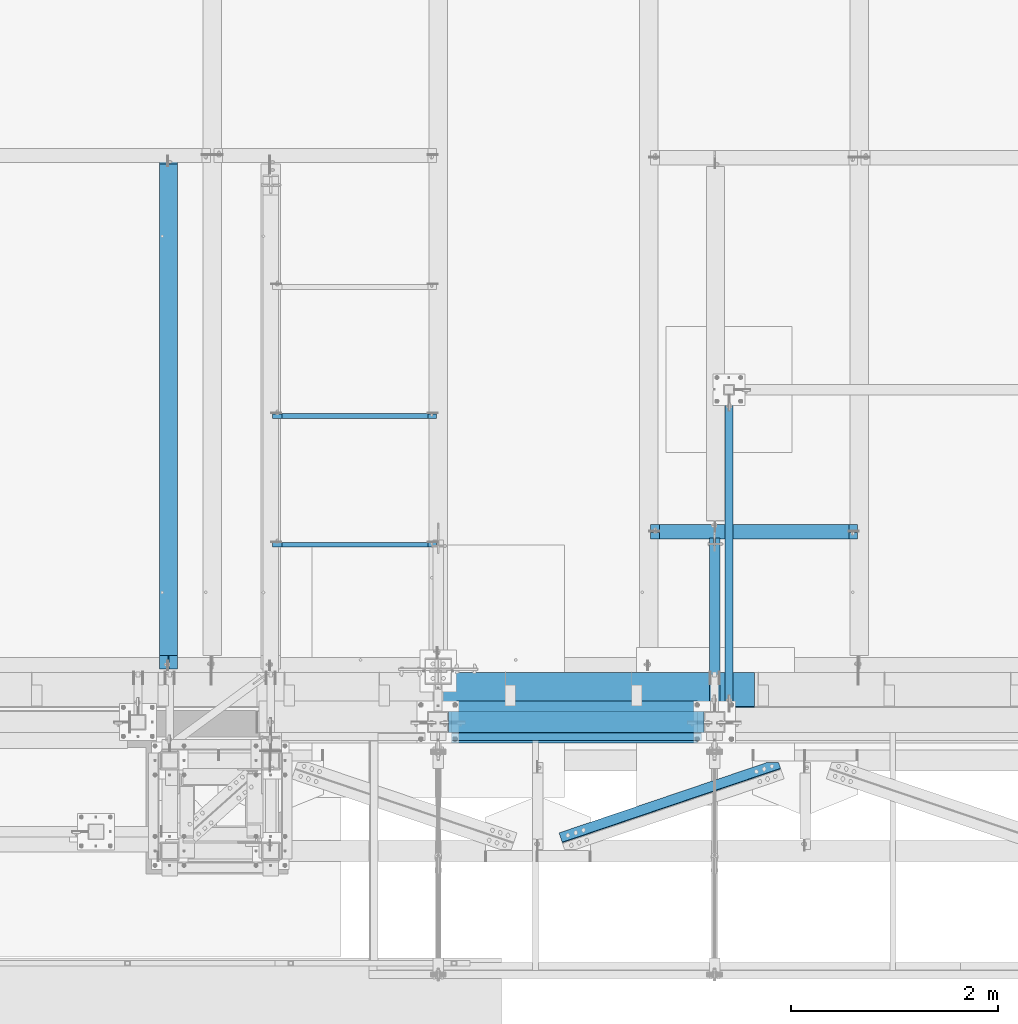
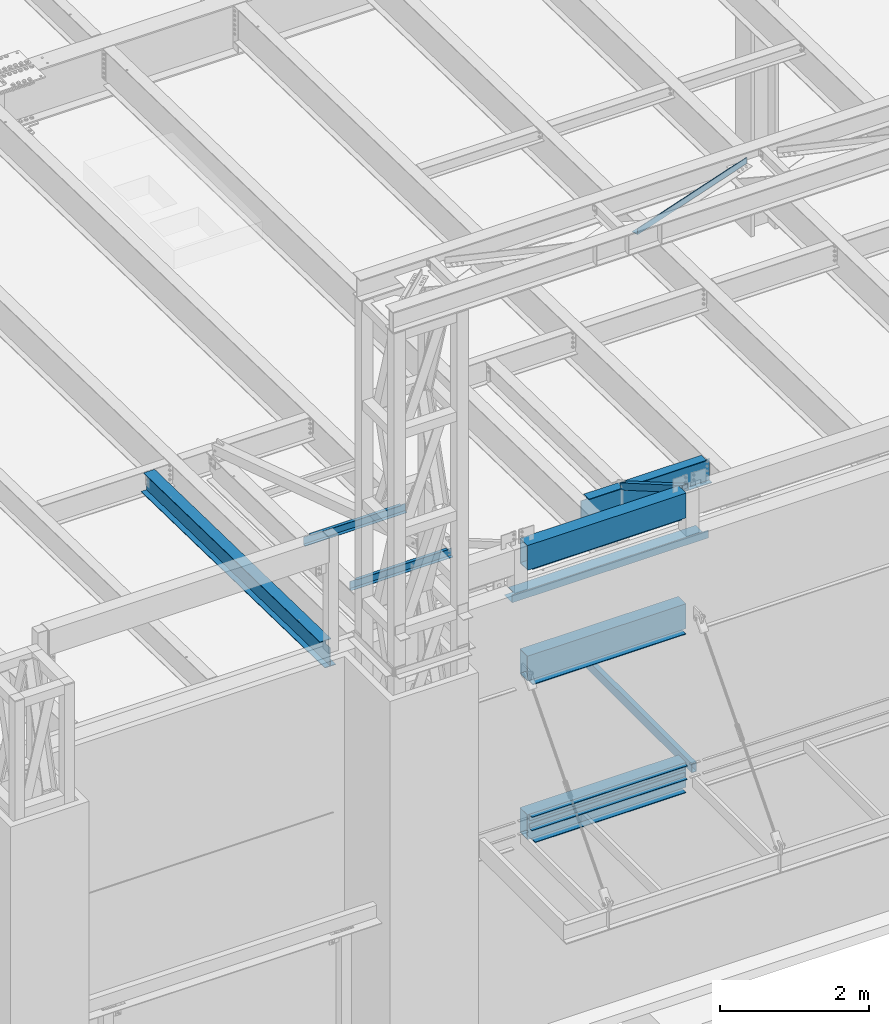
# One storey, part 1055 of 1763: 15 beams, 1 member, 11 elements without a shape of their own.
"""IFC2X3 building model written with IfcOpenShell, lengths in millimetres."""

from ifc_helpers import new_model, si_unit, frame, origin_with_axes, place, context, subcontext, project, spatial, faceted_brep, material, type_object, element, aggregate, save


model = new_model("IFC2X3")

# Units and contexts
model_context = context("Model", 3, precision=1e-05, world=origin_with_axes())
body_context = subcontext(model_context, "Body", "Model", "MODEL_VIEW")
ifc_project = project(units=[si_unit("LENGTHUNIT", "METRE", prefix="MILLI"), si_unit("AREAUNIT", "SQUARE_METRE"), si_unit("VOLUMEUNIT", "CUBIC_METRE"), si_unit("MASSUNIT", "GRAM", prefix="KILO"), si_unit("TIMEUNIT", "SECOND"), si_unit("PLANEANGLEUNIT", "RADIAN"), si_unit("SOLIDANGLEUNIT", "STERADIAN"), si_unit("THERMODYNAMICTEMPERATUREUNIT", "DEGREE_CELSIUS"), si_unit("LUMINOUSINTENSITYUNIT", "LUMEN")], contexts=[model_context])

# Site, building, storey
site_placement = place(None, origin_with_axes())
site = spatial("IfcSite", under=ifc_project, at=site_placement, CompositionType="ELEMENT")
building_placement = place(site_placement, origin_with_axes())
building = spatial("IfcBuilding", under=site, at=building_placement, Name="Undefined", CompositionType="ELEMENT")
storey_placement = place(building_placement, origin_with_axes())
storey = spatial("IfcBuildingStorey", under=building, at=storey_placement, Name="Undefined", CompositionType="ELEMENT", Elevation=0.0)

# Assembly, beam
assembly_1_placement = place(storey_placement, origin_with_axes())
assembly_1 = element("IfcElementAssembly", 1, at=assembly_1_placement, inside=storey, Name="BEAM", AssemblyPlace="NOTDEFINED", PredefinedType="RIGID_FRAME")
ifc_material_1 = material()
beam_type_1 = type_object("IfcBeamType", Name="HSS16X8X5/8", PredefinedType="NOTDEFINED")
beam_1_placement = place(assembly_1_placement, frame((-61492.8270098568, -14208.1276214906, 13055.6221257957), z_axis=(0.0, 0.0, 1.0), x_axis=(1.0, 0.0, 0.0)))
beam_1 = element("IfcBeam", 2, at=beam_1_placement, type_object=beam_type_1, material=ifc_material_1, Name="BEAM", ObjectType="HSS16X8X5/8", context=body_context, shape_type="Brep", body=[
    faceted_brep([(0.0, 85.7250000000058, -187.325), (0.0, -85.7250000000058, -187.325), (2463.80000000001, -85.7250000000004, -187.325000000001), (2463.80000000001, 85.7250000000004, -187.325000000001), (0.0, -85.7250000000058, 187.325), (2463.80000000001, -85.7250000000004, 187.325000000001), (0.0, 85.7250000000058, 187.325), (2463.80000000001, 85.7250000000004, 187.325000000001), (0.0, 101.600000000006, -203.2), (0.0, 101.600000000006, 203.2), (2463.80000000001, 101.6, 203.200000000001), (2463.80000000001, 101.6, -203.200000000001), (0.0, -101.600000000006, 203.2), (2463.80000000001, -101.6, 203.200000000001), (0.0, -101.600000000006, -203.2), (2463.80000000001, -101.6, -203.200000000001)], [[[0, 1, 2, 3]], [[1, 4, 5, 2]], [[4, 6, 7, 5]], [[6, 0, 3, 7]], [[8, 9, 10, 11]], [[9, 12, 13, 10]], [[12, 14, 15, 13]], [[14, 8, 11, 15]], [[13, 15, 11, 10], [5, 7, 3, 2]], [[14, 12, 9, 8], [6, 4, 1, 0]]]),
])

assembly_2_placement = place(storey_placement, origin_with_axes())
assembly_2 = element("IfcElementAssembly", 3, at=assembly_2_placement, inside=storey, Name="ANGLE", AssemblyPlace="NOTDEFINED", PredefinedType="RIGID_FRAME")
ifc_material_2 = material(Name="STEEL/A36")
beam_type_2 = type_object("IfcBeamType", Name="L4X4X1/4", PredefinedType="NOTDEFINED")
beam_2_placement = place(assembly_2_placement, frame((-60647.7195645886, -15404.6095930369, 18672.175), z_axis=(-0.320645554004404, 0.947199255013014, 0.0), x_axis=(0.947199255013015, 0.320645554004401, 0.0)))
beam_2 = element("IfcBeam", 4, at=beam_2_placement, type_object=beam_type_2, material=ifc_material_2, Name="ANGLE", ObjectType="L4X4X1/4", context=body_context, shape_type="Brep", body=[
    faceted_brep([(2473.98391933386, 44.4500000000007, 15.0708121723028), (2473.98391933386, 50.7999999999993, 15.0708121723028), (2368.34288178239, 50.7999999999993, 50.8000000014481), (2368.34288178239, 44.4500000000007, 50.8000000014481), (2473.9847329806, 44.4500000000007, -44.4499999985665), (2473.9847329806, -50.7999999999993, -44.4499999985665), (2473.98481932245, -50.7999999999993, -50.7999999985741), (2473.98481932245, 50.7999999999993, -50.7999999985741), (248.93475632761, 50.7999999999993, -50.7999999996973), (248.93475632761, -50.7999999999993, -50.7999999996973), (248.934670207287, -50.7999999999993, -44.449999999887), (248.934670207287, 44.4500000000007, -44.449999999887), (248.93336804508, 44.4500000000007, 50.8000000001894), (248.93336804508, 50.7999999999993, 50.8000000001894)], [[[0, 1, 2, 3]], [[4, 5, 6, 7, 1, 0]], [[8, 9, 10, 11, 12, 13]], [[13, 12, 3, 2]], [[8, 13, 2, 1, 7]], [[9, 8, 7, 6]], [[10, 9, 6, 5]], [[11, 10, 5, 4]], [[12, 11, 4, 0, 3]]]),
])
aggregate(assembly_2, [beam_2])

assembly_3_placement = place(storey_placement, origin_with_axes())
assembly_3 = element("IfcElementAssembly", 5, at=assembly_3_placement, inside=storey, Name="CHANNEL", AssemblyPlace="NOTDEFINED", PredefinedType="RIGID_FRAME")
beam_type_3 = type_object("IfcBeamType", Name="C6X8.2", PredefinedType="NOTDEFINED")
beam_3_placement = place(assembly_3_placement, frame((-63211.0608225783, -11251.4001198498, 12076.4773623998), z_axis=(0.0, 0.0, 1.0), x_axis=(1.0, 0.0, 0.0)))
beam_3 = element("IfcBeam", 6, at=beam_3_placement, type_object=beam_type_3, material=ifc_material_2, Name="CHANNEL", ObjectType="C6X8.2", context=body_context, shape_type="Brep", body=[
    faceted_brep([(94.4562501907349, 19.0499999999993, 50.7999999979074), (94.4562501907349, 23.8125, 50.7999999979074), (18.2562500000058, 23.8125, 50.7999999979074), (18.2562500000058, 19.0499999999993, 50.7999999979074), (99.3163297087813, 19.0499999999993, 51.766729920495), (99.3163297087813, 23.8125, 51.766729920495), (103.436506176935, 19.0499999999993, 54.5197438209725), (103.436506176935, 23.8125, 54.5197438209725), (106.189520077409, 19.0499999999993, 58.6399202891262), (106.189520077409, 23.8125, 58.6399202891262), (107.15625, 19.0499999999993, 63.4999998071726), (107.15625, 23.8125, 63.4999998071726), (107.15625, -23.8125, 76.2000000000007), (107.15625, 23.8125, 76.2000000000007), (107.15625, 19.0499999999993, 65.0887700000003), (107.15625, -23.8125, 72.2296624999999), (18.2562500000058, 19.0499999999993, -65.0887700000003), (18.2562500000058, -23.8125, -72.2296624999999), (1599.16104887993, -23.8125, -72.2296624999999), (1599.16104887993, 19.0499999999993, -65.0887700000003), (18.2562500000058, -23.8125, -76.2000000000007), (1599.16104887993, -23.8125, -76.2000000000007), (18.2562500000058, 23.8125, -76.2000000000007), (1599.16104887993, 23.8125, -76.2000000000007), (1599.16104887993, 23.8125, 50.8000000015836), (1599.16104887993, 19.0499999999993, 50.8000000015836), (1529.31104868917, 23.8125, 50.8000000015836), (1529.31104868917, 19.0499999999993, 50.8000000015836), (1524.45096917113, 23.8125, 51.7667299241712), (1524.45096917113, 19.0499999999993, 51.7667299241712), (1520.33079270297, 23.8125, 54.5197438246487), (1520.33079270297, 19.0499999999993, 54.5197438246487), (1517.5777788025, 23.8125, 58.6399202928023), (1517.5777788025, 19.0499999999993, 58.6399202928023), (1516.61104887991, 23.8125, 63.4999998108487), (1516.61104887991, 19.0499999999993, 63.4999998108487), (1516.61104887991, -23.8125, 76.2000000000007), (1516.61104887991, -23.8125, 72.2296624999999), (1516.61104887991, 19.0499999999993, 65.0887700000003), (1516.61104887991, 23.8125, 76.2000000000007)], [[[0, 1, 2, 3]], [[4, 5, 1, 0]], [[6, 7, 5, 4]], [[8, 9, 7, 6]], [[10, 11, 9, 8]], [[12, 13, 11, 10, 14, 15]], [[16, 17, 18, 19]], [[17, 20, 21, 18]], [[20, 22, 23, 21]], [[19, 18, 21, 23, 24, 25]], [[25, 24, 26, 27]], [[27, 26, 28, 29]], [[29, 28, 30, 31]], [[31, 30, 32, 33]], [[33, 32, 34, 35]], [[36, 37, 38, 35, 34, 39]], [[37, 36, 12, 15]], [[38, 37, 15, 14]], [[8, 6, 4, 0, 3, 16, 19, 25, 27, 29, 31, 33, 35, 38, 14, 10]], [[22, 20, 17, 16, 3, 2]], [[39, 34, 32, 30, 28, 26, 24, 23, 22, 2, 1, 5, 7, 9, 11, 13]], [[36, 39, 13, 12]]]),
])
aggregate(assembly_3, [beam_3])

assembly_4_placement = place(storey_placement, origin_with_axes())
assembly_4 = element("IfcElementAssembly", 7, at=assembly_4_placement, inside=storey, Name="CHANNEL", AssemblyPlace="NOTDEFINED", PredefinedType="RIGID_FRAME")
beam_4_placement = place(assembly_4_placement, frame((-63211.0608225783, -12495.6062192334, 12102.488636877), z_axis=(0.0, 0.0, 1.0), x_axis=(1.0, 0.0, 0.0)))
beam_4 = element("IfcBeam", 8, at=beam_4_placement, type_object=beam_type_3, material=ifc_material_2, Name="CHANNEL", ObjectType="C6X8.2", context=body_context, shape_type="Brep", body=[
    faceted_brep([(94.4562501907349, 19.0499999999993, 50.7999999979074), (94.4562501907349, 23.8125, 50.7999999979074), (18.2562500000058, 23.8125, 50.7999999979074), (18.2562500000058, 19.0499999999993, 50.7999999979074), (99.3163297087813, 19.0499999999993, 51.766729920495), (99.3163297087813, 23.8125, 51.766729920495), (103.436506176935, 19.0499999999993, 54.5197438209725), (103.436506176935, 23.8125, 54.5197438209725), (106.189520077409, 19.0499999999993, 58.6399202891262), (106.189520077409, 23.8125, 58.6399202891262), (107.15625, 19.0499999999993, 63.4999998071726), (107.15625, 23.8125, 63.4999998071726), (107.15625, -23.8125, 76.2000000000007), (107.15625, 23.8125, 76.2000000000007), (107.15625, 19.0499999999993, 65.0887700000003), (107.15625, -23.8125, 72.2296624999999), (18.2562500000058, 19.0499999999993, -65.0887700000003), (18.2562500000058, -23.8125, -72.2296624999999), (1599.16104887993, -23.8125, -72.2296624999999), (1599.16104887993, 19.0499999999993, -65.0887700000003), (18.2562500000058, -23.8125, -76.2000000000007), (1599.16104887993, -23.8125, -76.2000000000007), (18.2562500000058, 23.8125, -76.2000000000007), (1599.16104887993, 23.8125, -76.2000000000007), (1599.16104887993, 23.8125, 50.8000000015836), (1599.16104887993, 19.0499999999993, 50.8000000015836), (1529.31104868917, 23.8125, 50.8000000015836), (1529.31104868917, 19.0499999999993, 50.8000000015836), (1524.45096917113, 23.8125, 51.7667299241712), (1524.45096917113, 19.0499999999993, 51.7667299241712), (1520.33079270297, 23.8125, 54.5197438246487), (1520.33079270297, 19.0499999999993, 54.5197438246487), (1517.5777788025, 23.8125, 58.6399202928023), (1517.5777788025, 19.0499999999993, 58.6399202928023), (1516.61104887991, 23.8125, 63.4999998108487), (1516.61104887991, 19.0499999999993, 63.4999998108487), (1516.61104887991, -23.8125, 76.2000000000007), (1516.61104887991, -23.8125, 72.2296624999999), (1516.61104887991, 19.0499999999993, 65.0887700000003), (1516.61104887991, 23.8125, 76.2000000000007)], [[[0, 1, 2, 3]], [[4, 5, 1, 0]], [[6, 7, 5, 4]], [[8, 9, 7, 6]], [[10, 11, 9, 8]], [[12, 13, 11, 10, 14, 15]], [[16, 17, 18, 19]], [[17, 20, 21, 18]], [[20, 22, 23, 21]], [[19, 18, 21, 23, 24, 25]], [[25, 24, 26, 27]], [[27, 26, 28, 29]], [[29, 28, 30, 31]], [[31, 30, 32, 33]], [[33, 32, 34, 35]], [[36, 37, 38, 35, 34, 39]], [[37, 36, 12, 15]], [[38, 37, 15, 14]], [[8, 6, 4, 0, 3, 16, 19, 25, 27, 29, 31, 33, 35, 38, 14, 10]], [[22, 20, 17, 16, 3, 2]], [[39, 34, 32, 30, 28, 26, 24, 23, 22, 2, 1, 5, 7, 9, 11, 13]], [[36, 39, 13, 12]]]),
])
aggregate(assembly_4, [beam_4])

assembly_5_placement = place(storey_placement, origin_with_axes())
assembly_5 = element("IfcElementAssembly", 9, at=assembly_5_placement, inside=storey, Name="BEAM", AssemblyPlace="NOTDEFINED", PredefinedType="RIGID_FRAME")
beam_type_4 = type_object("IfcBeamType", Name="HSS16X8X1/4", PredefinedType="NOTDEFINED")
beam_5_placement = place(assembly_5_placement, frame((-61492.8270098568, -14208.1276214906, 11239.5), z_axis=(0.0, 0.0, 1.0), x_axis=(1.0, 0.0, 0.0)))
beam_5 = element("IfcBeam", 10, at=beam_5_placement, type_object=beam_type_4, material=ifc_material_1, Name="BEAM", ObjectType="HSS16X8X1/4", context=body_context, shape_type="Brep", body=[
    faceted_brep([(0.0, 95.25, -196.85), (0.0, -95.25, -196.85), (2463.80000000001, -95.25, -196.85), (2463.80000000001, 95.25, -196.85), (0.0, -95.25, 196.85), (2463.80000000001, -95.25, 196.85), (0.0, 95.25, 196.85), (2463.80000000001, 95.25, 196.85), (0.0, 101.600000000006, -203.2), (0.0, 101.600000000006, 203.2), (2463.80000000001, 101.6, 203.200000000001), (2463.80000000001, 101.6, -203.200000000001), (0.0, -101.600000000006, 203.2), (2463.80000000001, -101.6, 203.200000000001), (0.0, -101.600000000006, -203.2), (2463.80000000001, -101.6, -203.200000000001)], [[[0, 1, 2, 3]], [[1, 4, 5, 2]], [[4, 6, 7, 5]], [[6, 0, 3, 7]], [[8, 9, 10, 11]], [[9, 12, 13, 10]], [[12, 14, 15, 13]], [[14, 8, 11, 15]], [[13, 15, 11, 10], [5, 7, 3, 2]], [[14, 12, 9, 8], [6, 4, 1, 0]]]),
])

assembly_6_placement = place(storey_placement, origin_with_axes())
assembly_6 = element("IfcElementAssembly", 11, at=assembly_6_placement, inside=storey, Name="BEAM", AssemblyPlace="NOTDEFINED", PredefinedType="RIGID_FRAME")
beam_6_placement = place(assembly_6_placement, frame((-61492.8270098568, -14208.1276214906, 8636.0), z_axis=(0.0, 0.0, 1.0), x_axis=(1.0, 0.0, 0.0)))
beam_6 = element("IfcBeam", 12, at=beam_6_placement, type_object=beam_type_4, material=ifc_material_1, Name="BEAM", ObjectType="HSS16X8X1/4", context=body_context, shape_type="Brep", body=[
    faceted_brep([(0.0, 95.25, -196.85), (0.0, -95.25, -196.85), (2463.80000000001, -95.25, -196.85), (2463.80000000001, 95.25, -196.85), (0.0, -95.25, 196.85), (2463.80000000001, -95.25, 196.85), (0.0, 95.25, 196.85), (2463.80000000001, 95.25, 196.85), (0.0, 101.600000000006, -203.2), (0.0, 101.600000000006, 203.2), (2463.80000000001, 101.6, 203.200000000001), (2463.80000000001, 101.6, -203.200000000001), (0.0, -101.600000000006, 203.2), (2463.80000000001, -101.6, 203.200000000001), (0.0, -101.600000000006, -203.2), (2463.80000000001, -101.6, -203.200000000001)], [[[0, 1, 2, 3]], [[1, 4, 5, 2]], [[4, 6, 7, 5]], [[6, 0, 3, 7]], [[8, 9, 10, 11]], [[9, 12, 13, 10]], [[12, 14, 15, 13]], [[14, 8, 11, 15]], [[13, 15, 11, 10], [5, 7, 3, 2]], [[14, 12, 9, 8], [6, 4, 1, 0]]]),
])

assembly_7_placement = place(storey_placement, origin_with_axes())
assembly_7 = element("IfcElementAssembly", 13, at=assembly_7_placement, inside=storey, Name="BEAM", AssemblyPlace="NOTDEFINED", PredefinedType="RIGID_FRAME")
ifc_material_3 = material(Name="STEEL/A992")
beam_type_5 = type_object("IfcBeamType", Name="W14X30", PredefinedType="NOTDEFINED")
beam_7_placement = place(assembly_7_placement, frame((-64197.556794258, -13719.6833239361, 12028.5259948812), z_axis=(0.0, 0.0209013539966291, 0.999781542838788), x_axis=(0.0, 0.999781542776098, -0.0209013569953182)))
beam_7 = element("IfcBeam", 14, at=beam_7_placement, type_object=beam_type_5, material=ifc_material_3, Name="BEAM", ObjectType="W14X30", context=body_context, shape_type="Brep", body=[
    faceted_brep([(137.83239633108, -3.17500000000291, 125.152501678478), (137.83239633108, 3.17500000000291, 125.152501678478), (20.9159678208944, 3.17500000000291, 125.152501678522), (20.9159678208944, -3.17500000000291, 125.152501678522), (142.692475849137, -3.17500000000291, 126.119231601067), (142.692475849137, 3.17500000000291, 126.119231601067), (146.812652317303, -3.17500000000291, 128.87224550155), (146.812652317303, 3.17500000000291, 128.87224550155), (149.56566621779, -3.17500000000291, 132.992421969715), (149.56566621779, 3.17500000000291, 132.992421969715), (150.532396140381, -3.17500000000291, 137.852501487772), (150.532396140381, 3.17500000000291, 137.852501487772), (150.532396140394, -85.7249999999985, 176.212500000091), (150.532396140394, 85.7249999999985, 176.212500000091), (150.532396140392, 85.7249999999985, 166.687500000084), (150.532396140392, 3.17500000000291, 166.687500000084), (150.532396140392, -3.17500000000291, 166.687500000084), (150.532396140392, -85.7249999999985, 166.687500000084), (27.0171518537027, -3.17500000000291, -166.687500000153), (27.0171518537027, -85.7249999999985, -166.687500000153), (4969.20245516814, -85.7249999999985, -166.687500002057), (4969.20245516814, -3.17500000000291, -166.687500002057), (27.2162807516543, -85.7249999999985, -176.212500000162), (4969.40158406609, -85.7249999999985, -176.212500002064), (27.2162807516543, 85.7249999999985, -176.212500000162), (4969.40158406609, 85.7249999999985, -176.212500002064), (27.0171518537027, 85.7249999999985, -166.687500000153), (4969.20245516814, 85.7249999999985, -166.687500002057), (27.0171518537027, 3.17500000000291, -166.687500000153), (4969.20245516814, 3.17500000000291, -166.687500002057), (4962.70301333963, 3.17500000000291, 144.202501667336), (4962.70301333963, -3.17500000000291, 144.202501667336), (4908.56769927148, 3.17500000000291, 144.202501667358), (4908.56769927148, -3.17500000000291, 144.202501667358), (4903.70761975342, 3.17500000000291, 145.169231589949), (4903.70761975342, -3.17500000000291, 145.169231589949), (4899.58744328526, 3.17500000000291, 147.922245490434), (4899.58744328526, -3.17500000000291, 147.922245490434), (4896.83442938477, 3.17500000000291, 152.0424219586), (4896.83442938477, -3.17500000000291, 152.0424219586), (4895.86769946218, 3.17500000000291, 156.902501476661), (4895.86769946218, -3.17500000000291, 156.902501476661), (4895.86769946219, -85.7249999999985, 176.212499998263), (4895.86769946219, -85.7249999999985, 166.687499998254), (4895.86769946219, -3.17500000000291, 166.687499998254), (4895.86769946219, 3.17500000000291, 166.687499998254), (4895.86769946219, 85.7249999999985, 166.687499998254), (4895.86769946219, 85.7249999999985, 176.212499998263)], [[[0, 1, 2, 3]], [[4, 5, 1, 0]], [[6, 7, 5, 4]], [[8, 9, 7, 6]], [[10, 11, 9, 8]], [[12, 13, 14, 15, 11, 10, 16, 17]], [[18, 19, 20, 21]], [[19, 22, 23, 20]], [[22, 24, 25, 23]], [[24, 26, 27, 25]], [[26, 28, 29, 27]], [[21, 20, 23, 25, 27, 29, 30, 31]], [[31, 30, 32, 33]], [[33, 32, 34, 35]], [[35, 34, 36, 37]], [[37, 36, 38, 39]], [[39, 38, 40, 41]], [[42, 43, 44, 41, 40, 45, 46, 47]], [[43, 42, 12, 17]], [[44, 43, 17, 16]], [[8, 6, 4, 0, 3, 18, 21, 31, 33, 35, 37, 39, 41, 44, 16, 10]], [[28, 26, 24, 22, 19, 18, 3, 2]], [[45, 40, 38, 36, 34, 32, 30, 29, 28, 2, 1, 5, 7, 9, 11, 15]], [[46, 45, 15, 14]], [[47, 46, 14, 13]], [[42, 47, 13, 12]]]),
])
aggregate(assembly_7, [beam_7])

assembly_8_placement = place(storey_placement, origin_with_axes())
assembly_8 = element("IfcElementAssembly", 15, at=assembly_8_placement, inside=storey, Name="BEAM", AssemblyPlace="NOTDEFINED", PredefinedType="RIGID_FRAME")
beam_type_6 = type_object("IfcBeamType", Name="W16X26", PredefinedType="NOTDEFINED")
beam_8_placement = place(assembly_8_placement, frame((-59562.4372736983, -12372.1144876504, 11976.5798333454), z_axis=(0.0, 0.0, 1.0), x_axis=(1.0, 0.0, 0.0)))
beam_8 = element("IfcBeam", 16, at=beam_8_placement, type_object=beam_type_6, material=ifc_material_3, Name="BEAM", ObjectType="W16X26", context=body_context, shape_type="Brep", body=[
    faceted_brep([(87.312500190732, -3.17499999999927, 161.665001675578), (87.312500190732, 3.17499999999927, 161.665001675578), (17.4624999999942, 3.17499999999927, 161.665001675578), (17.4624999999942, -3.17499999999927, 161.665001675578), (92.1725797087784, -3.17499999999927, 162.631731598165), (92.1725797087784, 3.17499999999927, 162.631731598165), (96.292756176932, -3.17499999999927, 165.384745498643), (96.292756176932, 3.17499999999927, 165.384745498643), (97.1527139056197, -3.17499999999927, 166.671763191049), (97.1527139056197, 3.17499999999927, 166.671763191049), (17.4625000000087, -3.17499999999927, -190.5), (17.4625000000087, -69.8500000000004, -190.5), (2014.53750000001, -69.8500000000004, -190.5), (2014.53750000001, -3.17499999999927, -190.5), (17.4625000000087, -69.8500000000004, -200.025), (2014.53750000001, -69.8500000000004, -200.025), (17.4625000000087, 69.8500000000004, -200.025), (2014.53750000001, 69.8500000000004, -200.025), (17.4625000000087, 69.8500000000004, -190.5), (2014.53750000001, 69.8500000000004, -190.5), (17.4625000000087, 3.17499999999927, -190.5), (2014.53750000001, 3.17499999999927, -190.5), (2014.53750000001, 3.17499999999927, 161.665001678701), (2014.53750000001, -3.17499999999927, 161.665001678701), (1944.68749980927, 3.17499999999927, 161.665001678701), (1944.68749980927, -3.17499999999927, 161.665001678701), (1939.82742029122, 3.17499999999927, 162.631731601288), (1939.82742029122, -3.17499999999927, 162.631731601288), (1935.70724382307, 3.17499999999927, 165.384745501766), (1935.70724382307, -3.17499999999927, 165.384745501766), (1934.84728609816, 3.17499999999927, 166.671763188517), (1934.84728609816, -3.17499999999927, 166.671763188517), (1934.11974687481, 3.17499999999927, 167.157889355802), (1934.11974687481, -3.17499999999927, 167.157889355802), (1931.36673297434, 3.17499999999927, 171.278065823955), (1931.36673297434, -3.17499999999927, 171.278065823955), (1930.40000305175, 3.17499999999927, 176.138145342002), (1930.40000305175, -3.17499999999927, 176.138145342002), (101.599996948236, 3.17499999999927, 190.5), (101.599996948236, 69.8500000000004, 190.5), (1930.40000305175, 69.8500000000004, 190.5), (1930.40000305175, 3.17499999999927, 190.5), (101.599996948236, -69.8500000000004, 200.025), (101.599996948236, -69.8500000000004, 190.5), (1930.40000305175, -69.8500000000004, 190.5), (1930.40000305175, -69.8500000000004, 200.025), (101.599996948236, 69.8500000000004, 200.025), (1930.40000305175, 69.8500000000004, 200.025), (1930.40000305175, -3.17499999999927, 190.5), (101.599996948236, -3.17499999999927, 190.5), (101.599996948236, 3.17499999999927, 176.138145342), (101.599996948236, -3.17499999999927, 176.138145342), (100.633267025645, 3.17499999999927, 171.278065823954), (100.633267025645, -3.17499999999927, 171.278065823954), (97.8802531251713, 3.17499999999927, 167.1578893558), (97.8802531251713, -3.17499999999927, 167.1578893558)], [[[0, 1, 2, 3]], [[4, 5, 1, 0]], [[6, 7, 5, 4]], [[8, 9, 7, 6]], [[10, 11, 12, 13]], [[11, 14, 15, 12]], [[14, 16, 17, 15]], [[16, 18, 19, 17]], [[18, 20, 21, 19]], [[13, 12, 15, 17, 19, 21, 22, 23]], [[23, 22, 24, 25]], [[25, 24, 26, 27]], [[27, 26, 28, 29]], [[29, 28, 30, 31]], [[32, 33, 31, 30]], [[33, 32, 34, 35]], [[35, 34, 36, 37]], [[38, 39, 40, 41]], [[42, 43, 44, 45]], [[46, 42, 45, 47]], [[39, 46, 47, 40]], [[45, 44, 48, 37, 36, 41, 40, 47]], [[43, 49, 48, 44]], [[42, 46, 39, 38, 50, 51, 49, 43]], [[51, 50, 52, 53]], [[53, 52, 54, 55]], [[4, 0, 3, 10, 13, 23, 25, 27, 29, 31, 33, 35, 37, 48, 49, 51, 53, 55, 8, 6]], [[20, 18, 16, 14, 11, 10, 3, 2]], [[54, 52, 50, 38, 41, 36, 34, 32, 30, 28, 26, 24, 22, 21, 20, 2, 1, 5, 7, 9]], [[55, 54, 9, 8]]]),
])
aggregate(assembly_8, [beam_8])

# Assembly, member
assembly_9_placement = place(storey_placement, origin_with_axes())
assembly_9 = element("IfcElementAssembly", 17, at=assembly_9_placement, inside=storey, Name="V. BRACE", AssemblyPlace="NOTDEFINED", PredefinedType="RIGID_FRAME")
member_type = type_object("IfcMemberType", Name="HSS4X4X3/8", PredefinedType="NOTDEFINED")
member_placement = place(assembly_9_placement, frame((-58927.4372752341, -14106.5252728613, 13182.6000019665), z_axis=(0.0, 0.50173172990702, 0.865023277839683), x_axis=(0.0, 0.865023198927323, -0.501731865957846)))
member = element("IfcMember", 18, at=member_placement, type_object=member_type, material=ifc_material_1, Name="V. BRACE", ObjectType="HSS4X4X3/8", context=body_context, shape_type="Brep", body=[
    faceted_brep([(1908.23772841777, 7.93799800872512, 50.8000000000602), (1825.68772536952, 7.93799800872512, 50.8000000000566), (1825.68772536952, 7.93799800872512, 41.2750000000642), (1908.23772841777, 7.93799800872512, 41.2750000000669), (1825.68772536952, -7.93700008401356, 50.8000000000566), (1825.68772536952, -7.93700008401356, 41.2750000000642), (1908.23772842113, -7.93700008392625, 50.800000000062), (1908.23772841777, -7.93700008392625, 41.2750000000669), (1908.23772841777, 7.93799800872512, -41.2749999998796), (1825.68772536953, 7.93799800872512, -41.274999999885), (1825.68772536953, 7.93799800872512, -50.7999999998774), (1908.23772841777, 7.93799800872512, -50.7999999998729), (1825.68772536953, -7.93700008401356, -41.274999999885), (1825.68772536953, -7.93700008401356, -50.7999999998774), (1908.23772842113, -7.93700008392625, -41.2749999998796), (1908.23772841777, -7.93700008392625, -50.7999999998729), (-23.943093575228, 41.2750000000015, 41.2749999999705), (23.9376633641841, 41.2750000000015, -41.2749999999724), (1908.23772841777, 41.2750000000015, -41.2749999998796), (1908.23772841777, 41.2750000000015, 41.2750000000669), (1908.23772841777, -41.2750000000015, 41.2750000000669), (-23.943093575228, -41.2750000000015, 41.2749999999705), (23.9376633641841, -41.2750000000015, -41.2749999999724), (1908.23772841777, -41.2750000000015, -41.2749999998796), (29.4623660879624, -50.8000000000029, -50.7999999999665), (-29.4677962990063, -50.8000000000029, 50.7999999999647), (-29.4677962990063, 50.8000000000029, 50.7999999999647), (29.4623660879624, 50.8000000000029, -50.7999999999665), (1908.23772841777, 50.8000000000029, 50.8000000000602), (1908.23772841777, 50.8000000000029, -50.7999999998729), (1908.23772841777, -50.8000000000029, -50.7999999998729), (1908.23772841777, -50.8000000000029, 50.8000000000602)], [[[0, 1, 2, 3]], [[4, 5, 2, 1]], [[6, 7, 5, 4]], [[8, 9, 10, 11]], [[12, 13, 10, 9]], [[14, 15, 13, 12]], [[16, 17, 18, 19]], [[20, 21, 16, 19, 3, 2, 5, 7]], [[22, 21, 20, 23]], [[9, 8, 18, 17, 22, 23, 14, 12]], [[24, 25, 26, 27], [16, 21, 22, 17]], [[27, 26, 28, 29]], [[19, 18, 8, 11, 29, 28, 0, 3]], [[30, 24, 27, 29, 11, 10, 13, 15]], [[25, 24, 30, 31]], [[1, 0, 28, 26, 25, 31, 6, 4]], [[31, 30, 15, 14, 23, 20, 7, 6]]]),
])
aggregate(assembly_9, [member])

# Beam
beam_type_7 = type_object("IfcBeamType", Name="L3X3X3/8", PredefinedType="NOTDEFINED")
beam_9_placement = place(assembly_6_placement, frame((-59054.4267579841, -14347.8276162522, 8648.7), z_axis=(0.0, -1.0, 0.0), x_axis=(-1.0, 0.0, 0.0)))
beam_9 = element("IfcBeam", 19, at=beam_9_placement, type_object=beam_type_7, material=ifc_material_2, Name="ANGLE", ObjectType="L3X3X3/8", context=body_context, shape_type="Brep", body=[
    faceted_brep([(0.0, 38.0999999999985, -38.1000000000004), (0.0, 38.0999999999985, 38.1000000000004), (2413.00045158158, 38.1000000000004, 38.1000000002041), (2413.00045158131, 38.1000000000004, -38.0999999997966), (1.45519152283669e-11, 28.5750000000007, 38.1000000000022), (2413.00045158158, 28.5750000000007, 38.1000000002041), (0.0, 28.5750000000007, -28.5750000000007), (2413.00045158135, 28.5750000000007, -28.574999999797), (0.0, -38.1000000000004, -28.5750000000007), (2413.00045158135, -38.1000000000004, -28.574999999797), (0.0, -38.0999999999985, -38.1000000000004), (2413.00045158131, -38.1000000000004, -38.0999999997966)], [[[0, 1, 2, 3]], [[1, 4, 5, 2]], [[4, 6, 7, 5]], [[6, 8, 9, 7]], [[8, 10, 11, 9]], [[10, 0, 3, 11]], [[5, 7, 9, 11, 3, 2]], [[10, 8, 6, 4, 1, 0]]]),
])

beam_type_8 = type_object("IfcBeamType", Name="L4X3X3/8", PredefinedType="NOTDEFINED")
beam_10_placement = place(assembly_6_placement, frame((-59054.426757984, -14347.827624501, 8788.4), z_axis=(0.0, 0.0, -1.0), x_axis=(-1.0, 0.0, 0.0)))
beam_10 = element("IfcBeam", 20, at=beam_10_placement, type_object=beam_type_8, material=ifc_material_2, Name="ANGLE", ObjectType="L4X3X3/8", context=body_context, shape_type="Brep", body=[
    faceted_brep([(1.45519152283669e-10, 38.0999999999985, -50.7999999999993), (1.45519152283669e-10, 38.0999999999985, 50.7999999999993), (2413.00045158115, 38.0999999997966, 50.7999999999993), (2413.00045158115, 38.0999999997966, -50.7999999999993), (1.09139364212751e-10, 28.5749999999989, 50.7999999999993), (2413.00045158119, 28.574999999797, 50.7999999999993), (1.09139364212751e-10, 28.5749999999989, -41.2749999999996), (2413.00045158119, 28.574999999797, -41.2749999999996), (-1.23691279441118e-10, -38.1000000000022, -41.2749999999996), (2413.00045158143, -38.1000000002041, -41.2749999999996), (-1.23691279441118e-10, -38.1000000000022, -50.7999999999993), (2413.00045158143, -38.1000000002041, -50.7999999999993)], [[[0, 1, 2, 3]], [[1, 4, 5, 2]], [[4, 6, 7, 5]], [[6, 8, 9, 7]], [[8, 10, 11, 9]], [[10, 0, 3, 11]], [[5, 7, 9, 11, 3, 2]], [[10, 8, 6, 4, 1, 0]]]),
])

beam_type_9 = type_object("IfcBeamType", PredefinedType="NOTDEFINED")
beam_11_placement = place(assembly_1_placement, frame((-61416.6283737788, -14157.3276482409, 12846.1125760023), z_axis=(0.0, 1.0, 0.0), x_axis=(0.999999999994883, 4.99999977045952e-09, -3.19899999977773e-06)))
beam_11 = element("IfcBeam", 21, at=beam_11_placement, type_object=beam_type_9, material=ifc_material_2, Name="PLATE", context=body_context, shape_type="Brep", body=[
    faceted_brep([(-2.11002770811319e-10, 6.34999999999854, -152.4), (2.25554686039686e-10, 6.34999999999854, 152.4), (2324.09882571014, 6.34999999833235, 152.400000000935), (2324.09882570971, 6.34999999833235, -152.399999999066), (2.11002770811319e-10, -6.34999999999854, 152.399999999998), (2324.09882571011, -6.3500000016702, 152.400000000935), (-2.25554686039686e-10, -6.34999999999854, -152.400000000001), (2324.09882570968, -6.3500000016702, -152.399999999066)], [[[0, 1, 2, 3]], [[1, 4, 5, 2]], [[4, 6, 7, 5]], [[6, 0, 3, 7]], [[5, 7, 3, 2]], [[6, 4, 1, 0]]]),
])

aggregate(assembly_1, [beam_11, beam_1])

beam_12_placement = place(assembly_5_placement, frame((-61467.4270097933, -14258.9276215588, 11029.95), z_axis=(0.0, 1.0, 0.0), x_axis=(1.0, 0.0, 0.0)))
beam_12 = element("IfcBeam", 22, at=beam_12_placement, type_object=beam_type_9, material=ifc_material_2, Name="PLATE", context=body_context, shape_type="Brep", body=[
    faceted_brep([(-2.11002770811319e-10, 6.34999999999854, -152.4), (2.25554686039686e-10, 6.34999999999854, 152.4), (2374.89882572681, 6.35000000000036, 152.400000000955), (2374.89882572638, 6.35000000000036, -152.399999999045), (2.11002770811319e-10, -6.34999999999854, 152.399999999998), (2374.89882572681, -6.35000000000036, 152.400000000955), (-2.25554686039686e-10, -6.34999999999854, -152.400000000001), (2374.89882572638, -6.35000000000036, -152.399999999045)], [[[0, 1, 2, 3]], [[1, 4, 5, 2]], [[4, 6, 7, 5]], [[6, 0, 3, 7]], [[5, 7, 3, 2]], [[6, 4, 1, 0]]]),
])

aggregate(assembly_5, [beam_12, beam_5])

beam_13_placement = place(assembly_6_placement, frame((-61429.3270097932, -14258.9276215541, 8426.45), z_axis=(0.0, 1.0, 0.0), x_axis=(1.0, 0.0, 0.0)))
beam_13 = element("IfcBeam", 23, at=beam_13_placement, type_object=beam_type_9, material=ifc_material_2, Name="PLATE", context=body_context, shape_type="Brep", body=[
    faceted_brep([(-2.11002770811319e-10, 6.34999999999854, -152.4), (2.25554686039686e-10, 6.34999999999854, 152.4), (2336.79882572681, 6.35000000000036, 152.400000000938), (2336.79882572638, 6.35000000000036, -152.399999999061), (2.11002770811319e-10, -6.34999999999854, 152.399999999998), (2336.79882572681, -6.35000000000036, 152.400000000938), (-2.25554686039686e-10, -6.34999999999854, -152.400000000001), (2336.79882572638, -6.35000000000036, -152.399999999061)], [[[0, 1, 2, 3]], [[1, 4, 5, 2]], [[4, 6, 7, 5]], [[6, 0, 3, 7]], [[5, 7, 3, 2]], [[6, 4, 1, 0]]]),
])

aggregate(assembly_6, [beam_9, beam_10, beam_13, beam_6])

# Assembly, beam
assembly_10_placement = place(storey_placement, origin_with_axes())
assembly_10 = element("IfcElementAssembly", 24, at=assembly_10_placement, inside=storey, Name="BEAM", AssemblyPlace="NOTDEFINED", PredefinedType="RIGID_FRAME")
beam_type_10 = type_object("IfcBeamType", PredefinedType="NOTDEFINED")
beam_14_placement = place(assembly_10_placement, frame((-60067.2622736984, -13728.6998186171, 12207.875), z_axis=(-1.0, 0.0, 0.0), x_axis=(0.0, -1.0, 0.0)))
beam_14 = element("IfcBeam", 25, at=beam_14_placement, type_object=beam_type_10, material=ifc_material_2, Name="BENT_PLATE", context=body_context, shape_type="Brep", body=[
    faceted_brep([(127.000180053716, -3.17499999999927, 1387.47500610352), (127.000180053716, 3.17499999999927, 1387.47500610352), (0.0, 3.17499999999927, 1387.47500610352), (0.0, -3.17499999999927, 1387.47500610352), (127.000180053716, -3.17499999999927, 1524.00000000002), (127.000180053716, 3.17499999999927, 1524.0), (336.550018310547, -3.17499999999927, -1524.0), (0.0, -3.17499999999927, -1523.99999999999), (0.0, 3.17499999999927, -1523.99999999999), (330.200016784669, 3.17499999999927, -1524.0), (330.19998779297, 123.824998474123, -1524.0), (336.549987792969, 123.825000000001, -1524.0), (330.200016784669, 3.17499999999927, 1524.0), (330.19998779297, 123.824998474123, 1524.0), (336.549987792969, 123.825000000001, 1524.0), (336.550018310547, -3.17499999999927, 1524.0)], [[[0, 1, 2, 3]], [[4, 5, 1, 0]], [[6, 7, 8, 9, 10, 11]], [[9, 12, 13, 10]], [[14, 11, 10, 13]], [[15, 6, 11, 14]], [[3, 7, 6, 15, 4, 0]], [[8, 7, 3, 2]], [[12, 9, 8, 2, 1, 5]], [[15, 14, 13, 12, 5, 4]]]),
])
aggregate(assembly_10, [beam_14])

assembly_11_placement = place(storey_placement, origin_with_axes())
assembly_11 = element("IfcElementAssembly", 26, at=assembly_11_placement, inside=storey, Name="BEAM", AssemblyPlace="NOTDEFINED", PredefinedType="RIGID_FRAME")
beam_type_11 = type_object("IfcBeamType", Name="HSS6X3X3/16", PredefinedType="NOTDEFINED")
beam_15_placement = place(assembly_11_placement, frame((-58787.7367866828, -14106.5275948466, 8547.1), z_axis=(0.0, 0.0, 1.0), x_axis=(0.0, 1.0, 0.0)))
beam_15 = element("IfcBeam", 27, at=beam_15_placement, type_object=beam_type_11, material=ifc_material_1, Name="BEAM", ObjectType="HSS6X3X3/16", context=body_context, shape_type="Brep", body=[
    faceted_brep([(1.20053300634027e-10, 33.3375000000015, -71.4375), (-1.21872290037572e-10, -33.3375000000015, -71.4375), (3055.94005206906, -33.3374999902444, -71.4375), (3055.9400520693, 33.3375000097585, -71.4375), (-1.21872290037572e-10, -33.3375000000015, 71.4375), (3055.94005206906, -33.3374999902444, 71.4375), (1.20053300634027e-10, 33.3375000000015, 71.4375), (3055.9400520693, 33.3375000097585, 71.4375), (1.38243194669485e-10, 38.0999999999985, -76.2000000000007), (1.38243194669485e-10, 38.0999999999985, 76.2000000000007), (3055.94005206932, 38.1000000097556, 76.2000000000007), (3055.94005206932, 38.1000000097556, -76.2000000000007), (-1.40062184073031e-10, -38.0999999999985, 76.2000000000007), (3055.94005206904, -38.0999999902415, 76.2000000000007), (-1.40062184073031e-10, -38.0999999999985, -76.2000000000007), (3055.94005206904, -38.0999999902415, -76.2000000000007)], [[[0, 1, 2, 3]], [[1, 4, 5, 2]], [[4, 6, 7, 5]], [[6, 0, 3, 7]], [[8, 9, 10, 11]], [[9, 12, 13, 10]], [[12, 14, 15, 13]], [[14, 8, 11, 15]], [[13, 15, 11, 10], [5, 7, 3, 2]], [[14, 12, 9, 8], [6, 4, 1, 0]]]),
])
aggregate(assembly_11, [beam_15])

save(model, "model.ifc")
